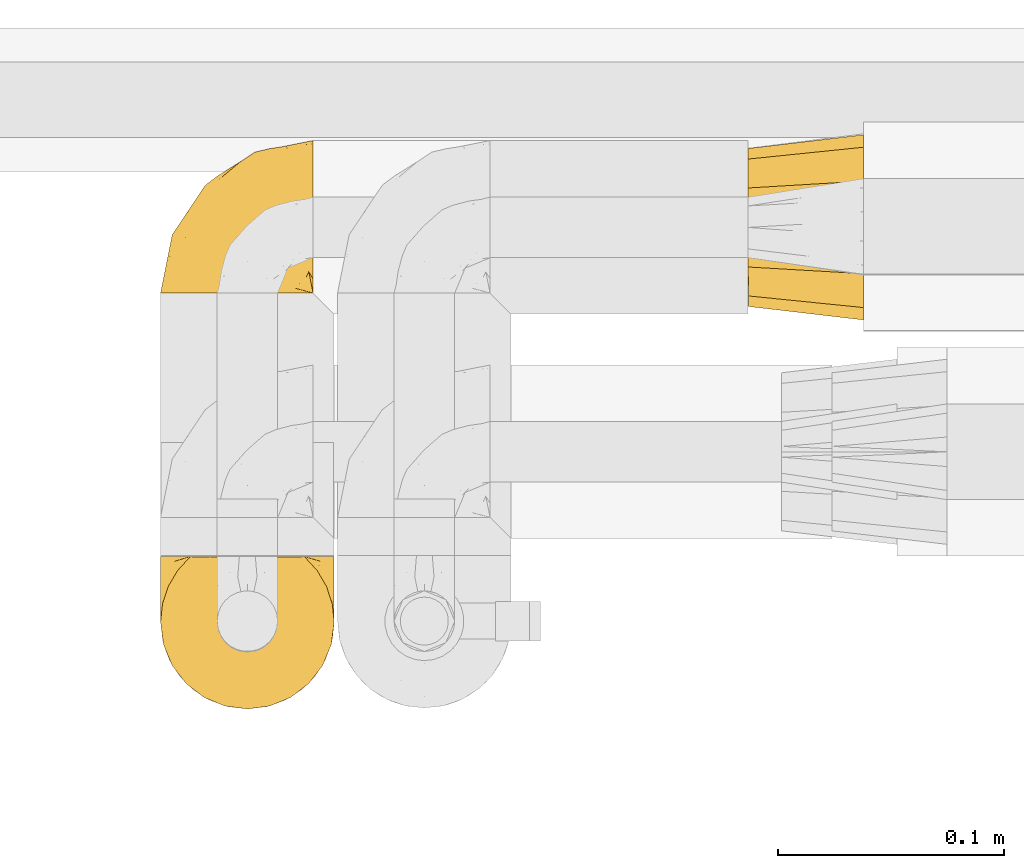
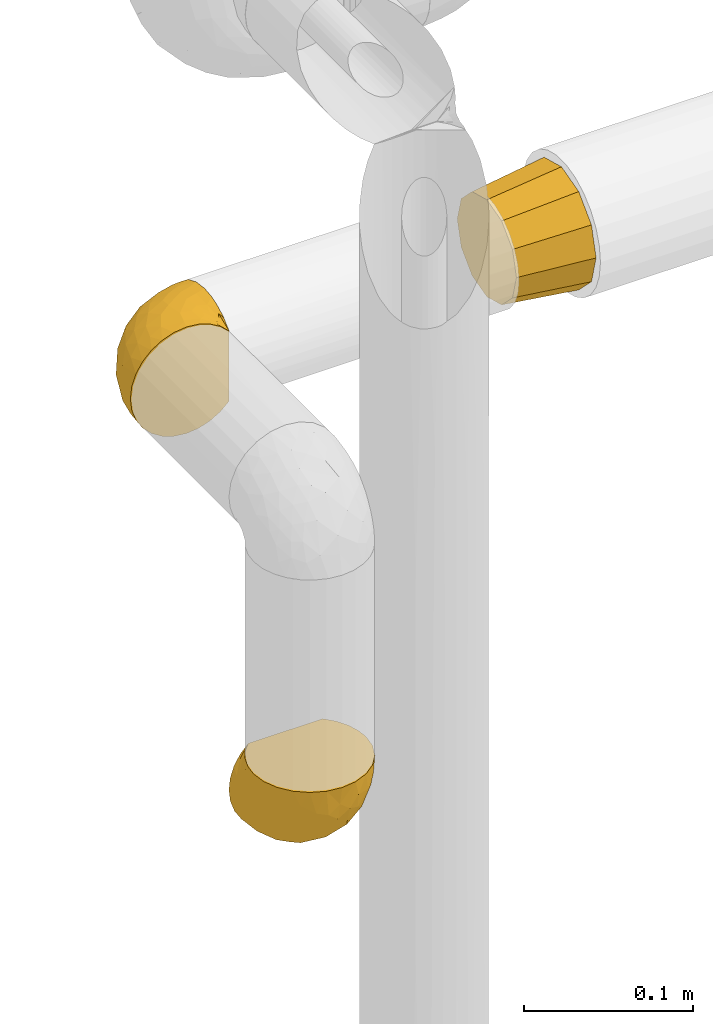
# One storey, part 470 of 827: 3 coverings.
"""IFC2X3 building model written with IfcOpenShell, lengths in millimetres."""

from ifc_helpers import new_model, entity, si_unit, converted_unit, derived_unit, direction, frame, origin, place, context, subcontext, project, spatial, faceted_brep, element, save


model = new_model("IFC2X3")

# Units and contexts
model_context = context("Model", 3, precision=0.01, world=origin(), true_north=direction((6.12303176911189e-17, 1.0)))
body_context = subcontext(model_context, "Body", "Model", "MODEL_VIEW")
ifc_project = project(units=[si_unit("LENGTHUNIT", "METRE", prefix="MILLI"), si_unit("AREAUNIT", "SQUARE_METRE"), si_unit("VOLUMEUNIT", "CUBIC_METRE"), converted_unit("PLANEANGLEUNIT", "DEGREE", entity("IfcRatioMeasure", 0.0174532925199433), si_unit("PLANEANGLEUNIT", "RADIAN"), dimensions=[0, 0, 0, 0, 0, 0, 0]), si_unit("MASSUNIT", "GRAM", prefix="KILO"), derived_unit("MASSDENSITYUNIT", [(si_unit("MASSUNIT", "GRAM", prefix="KILO"), 1), (si_unit("LENGTHUNIT", "METRE"), -3)]), derived_unit("MOMENTOFINERTIAUNIT", [(si_unit("LENGTHUNIT", "METRE"), 4)]), si_unit("TIMEUNIT", "SECOND"), si_unit("FREQUENCYUNIT", "HERTZ"), si_unit("THERMODYNAMICTEMPERATUREUNIT", "DEGREE_CELSIUS"), derived_unit("THERMALTRANSMITTANCEUNIT", [(si_unit("MASSUNIT", "GRAM", prefix="KILO"), 1), (si_unit("THERMODYNAMICTEMPERATUREUNIT", "KELVIN"), -1), (si_unit("TIMEUNIT", "SECOND"), -3)]), derived_unit("VOLUMETRICFLOWRATEUNIT", [(si_unit("LENGTHUNIT", "METRE"), 3), (si_unit("TIMEUNIT", "SECOND"), -1)]), derived_unit("MASSFLOWRATEUNIT", [(si_unit("MASSUNIT", "GRAM", prefix="KILO"), 1), (si_unit("TIMEUNIT", "SECOND"), -1)]), derived_unit("ROTATIONALFREQUENCYUNIT", [(si_unit("TIMEUNIT", "SECOND"), -1)]), si_unit("ELECTRICCURRENTUNIT", "AMPERE"), si_unit("ELECTRICVOLTAGEUNIT", "VOLT"), si_unit("POWERUNIT", "WATT"), si_unit("FORCEUNIT", "NEWTON", prefix="KILO"), si_unit("ILLUMINANCEUNIT", "LUX"), si_unit("LUMINOUSFLUXUNIT", "LUMEN"), si_unit("LUMINOUSINTENSITYUNIT", "CANDELA"), derived_unit("USERDEFINED", [(si_unit("MASSUNIT", "GRAM", prefix="KILO"), -1), (si_unit("LENGTHUNIT", "METRE"), -2), (si_unit("TIMEUNIT", "SECOND"), 3), (si_unit("LUMINOUSFLUXUNIT", "LUMEN"), 1)]), derived_unit("LINEARVELOCITYUNIT", [(si_unit("LENGTHUNIT", "METRE"), 1), (si_unit("TIMEUNIT", "SECOND"), -1)]), si_unit("PRESSUREUNIT", "PASCAL"), derived_unit("USERDEFINED", [(si_unit("LENGTHUNIT", "METRE"), -2), (si_unit("MASSUNIT", "GRAM", prefix="KILO"), 1), (si_unit("TIMEUNIT", "SECOND"), -2)]), derived_unit("LINEARFORCEUNIT", [(si_unit("MASSUNIT", "GRAM", prefix="KILO"), 1), (si_unit("LENGTHUNIT", "METRE"), 1), (si_unit("TIMEUNIT", "SECOND"), -2), (si_unit("LENGTHUNIT", "METRE"), -1)]), derived_unit("PLANARFORCEUNIT", [(si_unit("MASSUNIT", "GRAM", prefix="KILO"), 1), (si_unit("LENGTHUNIT", "METRE"), 1), (si_unit("TIMEUNIT", "SECOND"), -2), (si_unit("LENGTHUNIT", "METRE"), -2)])], contexts=[model_context])

# Site, building, storey
site_placement = place(None, origin())
site = spatial("IfcSite", under=ifc_project, at=site_placement, CompositionType="ELEMENT")
building_placement = place(site_placement, origin())
building = spatial("IfcBuilding", under=site, at=building_placement, CompositionType="ELEMENT")
storey_placement = place(building_placement, frame((0.0, 0.0, 28200.0)))
storey = spatial("IfcBuildingStorey", under=building, at=storey_placement, Name="08", CompositionType="ELEMENT", Elevation=28200.0)

# Coverings
covering_1_placement = place(storey_placement, frame((58451.15, 16448.53, 959.95)))
element("IfcCovering", 1, at=covering_1_placement, inside=storey, Name=":ADSK_", ObjectType=":ADSK_", PredefinedType="INSULATION", context=body_context, shape_type="Brep", body=[
    faceted_brep([(23.36, 1.6, 74.68), (16.07, 1.6, 70.1), (9.98, 1.6, 64.01), (5.4, 1.6, 56.72), (2.56, 1.6, 48.6), (1.6, 1.6, 40.05), (2.56, 1.6, 31.49), (5.41, 1.6, 23.36), (9.99, 1.6, 16.07), (16.08, 1.6, 9.98), (23.37, 1.6, 5.4), (31.49, 1.6, 2.56), (40.05, 1.6, 1.6), (48.15, 1.6, 2.46), (55.88, 1.6, 5.01), (62.9, 1.6, 9.13), (68.89, 1.6, 14.62), (68.89, 1.6, 16.82), (68.89, 1.6, 18.56), (68.89, 1.6, 20.52), (68.89, 1.6, 22.49), (68.89, 1.6, 24.46), (68.89, 1.6, 26.42), (68.89, 1.6, 28.39), (68.89, 1.6, 30.36), (68.89, 1.6, 32.55), (68.89, 1.6, 34.75), (68.89, 1.6, 36.94), (68.89, 1.6, 39.13), (68.89, 1.6, 41.33), (68.89, 1.6, 43.52), (68.89, 1.6, 45.72), (68.89, 1.6, 47.91), (68.89, 1.6, 50.11), (68.89, 1.6, 52.3), (68.89, 1.6, 54.49), (68.89, 1.6, 56.69), (68.89, 1.6, 58.88), (68.89, 1.6, 61.08), (68.89, 1.6, 63.27), (68.89, 1.6, 65.47), (62.89, 1.6, 70.97), (55.86, 1.6, 75.09), (48.13, 1.6, 77.64), (40.05, 1.6, 78.5), (31.49, 1.6, 77.53), (69.15, 1.85, 14.62), (69.15, 7.85, 9.12), (69.15, 14.87, 5.0), (69.15, 22.6, 2.46), (69.15, 30.7, 1.6), (69.15, 40.65, 2.91), (69.15, 49.92, 6.75), (69.15, 57.88, 12.86), (69.15, 63.99, 20.82), (69.15, 67.84, 30.09), (69.15, 69.15, 40.05), (69.15, 67.84, 50.0), (69.15, 63.99, 59.27), (69.15, 57.88, 67.23), (69.15, 49.92, 73.34), (69.15, 40.65, 77.19), (69.15, 30.7, 78.5), (69.15, 22.6, 77.63), (69.15, 14.87, 75.09), (69.15, 7.85, 70.97), (69.15, 1.85, 65.47), (69.15, 1.85, 63.27), (69.15, 1.85, 62.29), (69.15, 1.85, 60.7), (69.15, 1.85, 59.11), (69.15, 1.85, 57.52), (69.15, 1.85, 55.93), (69.15, 1.85, 54.34), (69.15, 1.85, 52.76), (69.15, 1.85, 51.17), (69.15, 1.85, 49.58), (69.15, 1.85, 47.99), (69.15, 1.85, 46.4), (69.15, 1.85, 44.81), (69.15, 1.85, 43.22), (69.15, 1.85, 41.63), (69.15, 1.85, 40.05), (69.15, 1.85, 38.46), (69.15, 1.85, 36.87), (69.15, 1.85, 35.28), (69.15, 1.85, 33.69), (69.15, 1.85, 32.1), (69.15, 1.85, 30.51), (69.15, 1.85, 28.92), (69.15, 1.85, 27.33), (69.15, 1.85, 25.37), (69.15, 1.85, 23.4), (69.15, 1.85, 21.21), (69.15, 1.85, 19.01), (69.15, 1.85, 16.82), (68.96, 1.77, 42.32), (68.97, 1.78, 44.02), (68.97, 1.77, 47.13), (68.97, 1.77, 48.74), (68.95, 1.76, 23.57), (68.96, 1.77, 25.13), (68.98, 1.79, 61.34), (68.97, 1.78, 22.02), (68.97, 1.78, 29.72), (68.98, 1.78, 56.73), (68.97, 1.78, 55.14), (68.97, 1.78, 37.66), (68.94, 1.74, 64.12), (68.98, 1.78, 28.13), (68.98, 1.78, 26.62), (68.96, 1.77, 31.46), (68.97, 1.78, 16.16), (68.98, 1.78, 39.16), (68.98, 1.78, 50.37), (68.97, 1.77, 17.69), (68.96, 1.77, 19.17), (68.97, 1.77, 62.78), (68.97, 1.78, 58.35), (68.98, 1.78, 45.53), (68.96, 1.77, 59.91), (68.97, 1.77, 65.47), (68.94, 1.72, 65.47), (68.92, 1.66, 65.47), (68.97, 1.77, 14.62), (69.02, 1.8, 14.62), (69.08, 1.82, 14.62), (68.98, 1.79, 20.59), (68.97, 1.78, 32.99), (68.98, 1.79, 34.48), (68.97, 1.78, 51.91), (69.08, 1.82, 65.47), (69.02, 1.8, 65.47), (68.96, 1.76, 53.48), (68.92, 1.66, 14.62), (68.94, 1.72, 14.62), (68.97, 1.78, 40.77), (68.96, 1.77, 35.97), (67.02, 9.41, 7.84), (63.33, 17.65, 3.53), (64.61, 7.41, 8.32), (49.27, 21.47, 1.6), (51.4, 15.21, 2.19), (43.94, 16.15, 1.6), (61.87, 28.75, 1.6), (61.54, 13.67, 4.57), (57.95, 12.79, 3.96), (56.12, 19.18, 2.28), (63.4, 29.16, 1.6), (65.41, 9.04, 7.69), (53.1, 7.41, 3.53), (63.04, 5.74, 8.32), (61.33, 3.72, 7.84), (41.99, 8.87, 1.6), (54.6, 26.8, 1.6), (56.6, 9.53, 4.34), (41.58, 7.34, 1.6), (13.72, 37.63, 29.63), (5.82, 17.92, 27.34), (6.74, 27.45, 40.05), (58.82, 37.01, 2.39), (51.58, 34.22, 2.43), (42.09, 45.87, 9.07), (46.12, 56.57, 16.64), (55.56, 52.31, 9.54), (52.38, 42.07, 4.52), (61.54, 44.74, 4.52), (23.76, 21.49, 7.49), (20.5, 11.02, 7.49), (14.64, 15.64, 12.85), (41.77, 26.02, 2.35), (16.28, 36.59, 22.66), (49.4, 65.49, 32.9), (52.34, 63.99, 25.33), (4.3, 15.2, 40.05), (58.67, 60.27, 16.64), (25.26, 45.25, 19.99), (20.17, 35.21, 16.37), (34.7, 22.52, 3.26), (28.67, 12.03, 3.75), (8.62, 13.32, 19.58), (33.37, 35.9, 7.5), (41.35, 33.87, 4.04), (17.15, 25.73, 13.94), (12.68, 26.34, 19.58), (21.47, 46.78, 28.21), (41.11, 59.54, 24.75), (37.53, 60.18, 31.42), (30.64, 53.93, 26.2), (26.66, 53.36, 33.36), (21.38, 49.36, 40.05), (14.06, 38.4, 40.05), (55.54, 66.44, 40.05), (35.17, 50.09, 16.14), (29.04, 41.08, 12.85), (24.34, 31.14, 10.47), (29.33, 28.19, 6.49), (43.3, 64.0, 40.05), (32.34, 56.68, 40.05), (57.75, 43.9, 75.57), (49.41, 65.46, 47.37), (27.85, 52.22, 52.91), (13.7, 37.61, 50.46), (14.63, 15.64, 67.23), (8.61, 13.31, 60.5), (48.85, 50.02, 70.55), (54.13, 59.28, 63.45), (37.84, 53.05, 62.61), (23.75, 21.48, 72.6), (20.49, 11.01, 72.6), (28.66, 12.03, 76.34), (20.83, 41.02, 59.34), (55.15, 35.39, 77.76), (54.6, 26.8, 78.5), (61.87, 28.75, 78.5), (41.58, 7.34, 78.5), (57.58, 65.81, 53.16), (59.91, 53.28, 70.55), (36.94, 59.8, 48.88), (45.72, 61.82, 54.76), (5.82, 17.91, 52.74), (37.91, 41.4, 71.93), (50.18, 40.48, 75.79), (12.67, 26.34, 60.5), (49.29, 31.68, 77.86), (42.64, 27.68, 77.64), (43.94, 16.15, 78.5), (49.27, 21.47, 78.5), (19.45, 28.05, 67.23), (34.7, 22.54, 76.82), (41.99, 8.87, 78.5), (62.29, 37.3, 77.8), (29.01, 41.07, 67.23), (31.47, 32.24, 73.2), (37.18, 47.4, 67.66), (43.45, 35.77, 75.99), (63.33, 17.65, 76.57), (67.23, 11.06, 73.21), (66.07, 8.55, 71.93), (65.22, 6.63, 71.07), (61.99, 12.77, 75.09), (57.95, 12.79, 76.13), (53.09, 7.41, 76.57), (56.84, 18.97, 77.69), (61.33, 3.72, 72.26), (63.06, 5.76, 71.77), (51.41, 15.21, 77.9), (56.61, 9.52, 75.75)], [[[0, 1, 2, 3, 4, 5, 6, 7, 8, 9, 10, 11, 12, 13, 14, 15, 16, 17, 18, 19, 20, 21, 22, 23, 24, 25, 26, 27, 28, 29, 30, 31, 32, 33, 34, 35, 36, 37, 38, 39, 40, 41, 42, 43, 44, 45]], [[46, 47, 48, 49, 50, 51, 52, 53, 54, 55, 56, 57, 58, 59, 60, 61, 62, 63, 64, 65, 66, 67, 68, 69, 70, 71, 72, 73, 74, 75, 76, 77, 78, 79, 80, 81, 82, 83, 84, 85, 86, 87, 88, 89, 90, 91, 92, 93, 94, 95]], [[96, 97, 30]], [[98, 77, 99]], [[100, 101, 21]], [[69, 68, 102]], [[20, 19, 103]], [[24, 23, 104]], [[20, 103, 100]], [[72, 105, 106]], [[84, 83, 107]], [[89, 88, 104]], [[108, 67, 66]], [[109, 110, 90]], [[111, 25, 24]], [[112, 17, 16]], [[82, 113, 83]], [[109, 23, 22]], [[114, 76, 75]], [[105, 36, 106]], [[104, 111, 24]], [[18, 115, 116]], [[97, 96, 80]], [[67, 108, 117]], [[105, 71, 118]], [[31, 97, 119]], [[102, 120, 69]], [[108, 121, 122, 123, 40]], [[112, 95, 115]], [[17, 115, 18]], [[94, 116, 115]], [[117, 68, 67]], [[38, 117, 39]], [[112, 124, 125, 126, 46]], [[17, 112, 115]], [[70, 120, 118]], [[39, 117, 108]], [[120, 38, 37]], [[120, 37, 118]], [[120, 70, 69]], [[116, 94, 127]], [[128, 86, 129]], [[117, 38, 102]], [[74, 130, 75]], [[99, 33, 32]], [[115, 95, 94]], [[39, 108, 40]], [[108, 66, 131, 132, 121]], [[105, 72, 71]], [[118, 37, 36]], [[71, 70, 118]], [[35, 106, 36]], [[36, 105, 118]], [[35, 133, 106]], [[74, 73, 133]], [[106, 133, 73]], [[99, 114, 33]], [[133, 35, 34]], [[73, 72, 106]], [[95, 112, 46]], [[112, 16, 134, 135, 124]], [[130, 114, 75]], [[99, 76, 114]], [[114, 130, 33]], [[34, 33, 130]], [[78, 77, 98]], [[98, 119, 78]], [[130, 133, 34]], [[133, 130, 74]], [[79, 97, 80]], [[98, 99, 32]], [[98, 32, 31]], [[77, 76, 99]], [[97, 79, 119]], [[136, 96, 29]], [[30, 97, 31]], [[136, 29, 28]], [[81, 80, 96]], [[29, 96, 30]], [[31, 119, 98]], [[119, 79, 78]], [[96, 136, 81]], [[82, 81, 136]], [[113, 107, 83]], [[84, 107, 137]], [[107, 27, 137]], [[113, 28, 107]], [[27, 107, 28]], [[85, 84, 137]], [[137, 27, 26]], [[113, 136, 28]], [[136, 113, 82]], [[109, 89, 104]], [[86, 85, 129]], [[89, 109, 90]], [[111, 87, 128]], [[26, 129, 137]], [[88, 111, 104]], [[25, 111, 128]], [[22, 110, 109]], [[23, 109, 104]], [[110, 91, 90]], [[100, 92, 101]], [[110, 22, 101]], [[91, 110, 101]], [[116, 19, 18]], [[111, 88, 87]], [[127, 103, 19]], [[25, 128, 26]], [[86, 128, 87]], [[128, 129, 26]], [[137, 129, 85]], [[120, 102, 38]], [[117, 102, 68]], [[91, 101, 92]], [[21, 101, 22]], [[93, 92, 103]], [[100, 21, 20]], [[100, 103, 92]], [[127, 93, 103]], [[93, 127, 94]], [[116, 127, 19]], [[126, 138, 47]], [[48, 138, 139]], [[140, 125, 124]], [[141, 142, 143]], [[144, 49, 139]], [[145, 140, 146]], [[48, 139, 49]], [[139, 145, 147]], [[49, 144, 148, 50]], [[126, 125, 149]], [[14, 13, 150]], [[151, 146, 140]], [[149, 140, 145]], [[152, 151, 135]], [[152, 14, 150]], [[16, 15, 134]], [[13, 153, 150]], [[124, 151, 140]], [[141, 147, 142]], [[14, 152, 15]], [[15, 152, 134]], [[47, 46, 126]], [[139, 154, 144]], [[138, 48, 47]], [[125, 140, 149]], [[135, 134, 152]], [[146, 155, 142]], [[145, 146, 147]], [[149, 139, 138]], [[147, 141, 154]], [[147, 146, 142]], [[139, 147, 154]], [[139, 149, 145]], [[149, 138, 126]], [[155, 146, 151]], [[150, 143, 142]], [[152, 155, 151]], [[150, 142, 155]], [[13, 12, 156, 153]], [[153, 143, 150]], [[152, 150, 155]], [[151, 124, 135]], [[157, 158, 159]], [[160, 154, 161]], [[162, 163, 164]], [[165, 166, 160]], [[167, 168, 169]], [[141, 170, 161]], [[156, 12, 11]], [[158, 157, 171]], [[172, 55, 173]], [[158, 6, 174]], [[175, 54, 53]], [[52, 166, 164]], [[52, 164, 53]], [[54, 175, 173]], [[166, 52, 51]], [[176, 177, 171]], [[178, 143, 179]], [[156, 11, 179]], [[8, 7, 180]], [[169, 9, 8]], [[179, 143, 153, 156]], [[179, 11, 10]], [[168, 179, 10]], [[181, 162, 182]], [[179, 167, 178]], [[183, 184, 177]], [[183, 169, 184]], [[176, 171, 185]], [[172, 186, 187]], [[158, 7, 6]], [[159, 158, 174]], [[184, 180, 158]], [[54, 173, 55]], [[180, 169, 8]], [[188, 189, 187]], [[9, 168, 10]], [[186, 188, 187]], [[190, 157, 159, 191]], [[55, 172, 192]], [[176, 193, 194]], [[161, 170, 182]], [[162, 164, 165]], [[175, 164, 163]], [[51, 50, 148]], [[167, 195, 196]], [[178, 182, 170]], [[6, 5, 174]], [[158, 180, 7]], [[169, 180, 184]], [[169, 168, 9]], [[179, 168, 167]], [[182, 162, 165]], [[162, 194, 193]], [[161, 165, 160]], [[195, 181, 196]], [[192, 172, 197]], [[192, 56, 55]], [[189, 190, 198]], [[198, 197, 187]], [[172, 187, 197]], [[185, 189, 188]], [[198, 187, 189]], [[186, 172, 173]], [[173, 163, 186]], [[193, 186, 163]], [[176, 185, 188]], [[185, 157, 190]], [[188, 186, 193]], [[177, 176, 194]], [[188, 193, 176]], [[162, 193, 163]], [[195, 177, 194]], [[171, 177, 184]], [[181, 195, 194]], [[183, 167, 169]], [[162, 181, 194]], [[196, 182, 178]], [[158, 171, 184]], [[171, 157, 185]], [[177, 195, 183]], [[167, 183, 195]], [[182, 196, 181]], [[178, 170, 143]], [[178, 167, 196]], [[164, 175, 53]], [[173, 175, 163]], [[160, 51, 148]], [[164, 166, 165]], [[51, 160, 166]], [[160, 148, 144, 154]], [[141, 161, 154]], [[182, 165, 161]], [[190, 189, 185]], [[143, 170, 141]], [[60, 199, 61]], [[197, 200, 192]], [[201, 190, 202]], [[200, 57, 192]], [[203, 204, 2]], [[205, 206, 207]], [[208, 209, 210]], [[211, 207, 201]], [[212, 213, 214]], [[45, 215, 210]], [[216, 206, 58]], [[45, 44, 215]], [[59, 217, 60]], [[60, 217, 199]], [[0, 45, 210]], [[218, 201, 219]], [[202, 159, 220]], [[205, 221, 222]], [[223, 204, 203]], [[1, 203, 2]], [[57, 200, 216]], [[220, 3, 204]], [[220, 174, 4]], [[1, 0, 209]], [[212, 224, 213]], [[225, 226, 227]], [[228, 223, 203]], [[208, 210, 229]], [[210, 226, 229]], [[3, 220, 4]], [[58, 206, 59]], [[209, 203, 1]], [[202, 220, 223]], [[228, 203, 208]], [[202, 211, 201]], [[3, 2, 204]], [[202, 190, 191, 159]], [[210, 215, 230, 226]], [[199, 212, 231]], [[232, 233, 221]], [[233, 208, 229]], [[207, 206, 219]], [[217, 206, 205]], [[227, 224, 225]], [[233, 232, 228]], [[201, 207, 219]], [[234, 232, 221]], [[218, 219, 200]], [[202, 223, 211]], [[174, 220, 159]], [[174, 5, 4]], [[61, 231, 62]], [[220, 204, 223]], [[210, 209, 0]], [[203, 209, 208]], [[225, 233, 229]], [[224, 227, 213]], [[221, 233, 235]], [[57, 56, 192]], [[198, 218, 197]], [[200, 219, 216]], [[201, 198, 190]], [[197, 218, 200]], [[198, 201, 218]], [[206, 216, 219]], [[58, 57, 216]], [[231, 212, 214]], [[222, 212, 199]], [[228, 211, 223]], [[207, 211, 232]], [[62, 231, 214]], [[199, 231, 61]], [[233, 228, 208]], [[211, 228, 232]], [[222, 221, 235]], [[234, 205, 207]], [[206, 217, 59]], [[199, 217, 205]], [[205, 222, 199]], [[224, 222, 235]], [[222, 224, 212]], [[224, 235, 225]], [[233, 225, 235]], [[226, 225, 229]], [[205, 234, 221]], [[207, 232, 234]], [[63, 214, 236]], [[214, 213, 236]], [[214, 63, 62]], [[237, 236, 238]], [[238, 132, 131]], [[236, 237, 64]], [[239, 240, 241]], [[63, 236, 64]], [[131, 66, 65]], [[237, 131, 65]], [[242, 230, 43]], [[237, 65, 64]], [[239, 121, 132]], [[42, 242, 43]], [[241, 240, 243]], [[41, 123, 244]], [[43, 230, 215, 44]], [[244, 122, 245]], [[227, 246, 243]], [[241, 247, 245]], [[121, 239, 245]], [[41, 40, 123]], [[132, 238, 239]], [[244, 42, 41]], [[131, 237, 238]], [[240, 239, 238]], [[245, 239, 241]], [[247, 241, 246]], [[247, 244, 245]], [[238, 236, 240]], [[243, 236, 213]], [[236, 243, 240]], [[227, 226, 246]], [[243, 213, 227]], [[242, 246, 226]], [[243, 246, 241]], [[246, 242, 247]], [[244, 247, 242]], [[242, 226, 230]], [[42, 244, 242]], [[122, 244, 123]], [[122, 121, 245]]]),
])
covering_2_placement = place(storey_placement, frame((58451.15, 16264.34, 748.41)))
element("IfcCovering", 2, at=covering_2_placement, inside=storey, Name=":ADSK_", ObjectType=":ADSK_", PredefinedType="INSULATION", context=body_context, shape_type="Brep", body=[
    faceted_brep([(74.68, 69.15, 23.36), (70.1, 69.15, 16.07), (64.01, 69.15, 9.98), (56.72, 69.15, 5.4), (48.6, 69.15, 2.56), (40.05, 69.15, 1.6), (31.49, 69.15, 2.56), (23.36, 69.15, 5.41), (16.07, 69.15, 9.99), (9.98, 69.15, 16.08), (5.4, 69.15, 23.37), (2.56, 69.15, 31.49), (1.6, 69.15, 40.05), (2.46, 69.15, 48.15), (5.01, 69.15, 55.88), (9.13, 69.15, 62.9), (14.62, 69.15, 68.89), (16.82, 69.15, 68.89), (18.56, 69.15, 68.89), (20.52, 69.15, 68.89), (22.49, 69.15, 68.89), (24.46, 69.15, 68.89), (26.42, 69.15, 68.89), (28.39, 69.15, 68.89), (30.36, 69.15, 68.89), (32.55, 69.15, 68.89), (34.75, 69.15, 68.89), (36.94, 69.15, 68.89), (39.13, 69.15, 68.89), (41.33, 69.15, 68.89), (43.52, 69.15, 68.89), (45.72, 69.15, 68.89), (47.91, 69.15, 68.89), (50.11, 69.15, 68.89), (52.3, 69.15, 68.89), (54.49, 69.15, 68.89), (56.69, 69.15, 68.89), (58.88, 69.15, 68.89), (61.08, 69.15, 68.89), (63.27, 69.15, 68.89), (65.47, 69.15, 68.89), (70.97, 69.15, 62.89), (75.09, 69.15, 55.86), (77.64, 69.15, 48.13), (78.5, 69.15, 40.05), (77.53, 69.15, 31.49), (14.62, 68.89, 69.15), (9.12, 62.89, 69.15), (5.0, 55.87, 69.15), (2.46, 48.14, 69.15), (1.6, 40.05, 69.15), (2.91, 30.09, 69.15), (6.75, 20.82, 69.15), (12.86, 12.86, 69.15), (20.82, 6.75, 69.15), (30.09, 2.91, 69.15), (40.05, 1.6, 69.15), (50.0, 2.91, 69.15), (59.27, 6.75, 69.15), (67.23, 12.86, 69.15), (73.34, 20.82, 69.15), (77.19, 30.09, 69.15), (78.5, 40.05, 69.15), (77.63, 48.14, 69.15), (75.09, 55.87, 69.15), (70.97, 62.89, 69.15), (65.47, 68.89, 69.15), (63.27, 68.89, 69.15), (62.29, 68.89, 69.15), (60.7, 68.89, 69.15), (59.11, 68.89, 69.15), (57.52, 68.89, 69.15), (55.93, 68.89, 69.15), (54.34, 68.89, 69.15), (52.76, 68.89, 69.15), (51.17, 68.89, 69.15), (49.58, 68.89, 69.15), (47.99, 68.89, 69.15), (46.4, 68.89, 69.15), (44.81, 68.89, 69.15), (43.22, 68.89, 69.15), (41.63, 68.89, 69.15), (40.05, 68.89, 69.15), (38.46, 68.89, 69.15), (36.87, 68.89, 69.15), (35.28, 68.89, 69.15), (33.69, 68.89, 69.15), (32.1, 68.89, 69.15), (30.51, 68.89, 69.15), (28.92, 68.89, 69.15), (27.33, 68.89, 69.15), (25.37, 68.89, 69.15), (23.4, 68.89, 69.15), (21.21, 68.89, 69.15), (19.01, 68.89, 69.15), (16.82, 68.89, 69.15), (42.32, 68.97, 68.96), (44.02, 68.96, 68.97), (47.13, 68.97, 68.97), (48.74, 68.97, 68.97), (23.57, 68.98, 68.95), (25.13, 68.97, 68.96), (61.34, 68.96, 68.98), (22.02, 68.96, 68.97), (29.72, 68.96, 68.97), (56.73, 68.96, 68.98), (55.14, 68.96, 68.97), (37.66, 68.96, 68.97), (64.12, 69.0, 68.94), (28.13, 68.96, 68.98), (26.62, 68.96, 68.98), (31.46, 68.97, 68.96), (16.16, 68.96, 68.97), (39.16, 68.96, 68.98), (50.37, 68.96, 68.98), (17.69, 68.97, 68.97), (19.17, 68.97, 68.96), (62.78, 68.97, 68.97), (58.35, 68.96, 68.97), (45.53, 68.96, 68.98), (59.91, 68.97, 68.96), (65.47, 68.97, 68.97), (65.47, 69.02, 68.94), (65.47, 69.08, 68.92), (14.62, 68.97, 68.97), (14.62, 68.94, 69.02), (14.62, 68.92, 69.08), (20.59, 68.96, 68.98), (32.99, 68.96, 68.97), (34.48, 68.95, 68.98), (51.91, 68.96, 68.97), (65.47, 68.92, 69.08), (65.47, 68.94, 69.02), (53.48, 68.98, 68.96), (14.62, 69.08, 68.92), (14.62, 69.02, 68.94), (40.77, 68.96, 68.97), (35.97, 68.97, 68.96), (7.84, 61.33, 67.02), (3.53, 53.1, 63.33), (8.32, 63.33, 64.61), (1.6, 49.27, 49.27), (2.19, 55.53, 51.4), (1.6, 54.6, 43.94), (1.6, 41.99, 61.87), (4.57, 57.07, 61.54), (3.96, 57.95, 57.95), (2.28, 51.56, 56.12), (1.6, 41.58, 63.4), (7.69, 61.7, 65.41), (3.53, 63.33, 53.1), (8.32, 65.0, 63.04), (7.84, 67.02, 61.33), (1.6, 61.87, 41.99), (1.6, 43.94, 54.6), (4.34, 61.21, 56.6), (1.6, 63.4, 41.58), (29.63, 33.11, 13.72), (27.34, 52.82, 5.82), (40.05, 43.3, 6.74), (2.39, 33.73, 58.82), (2.43, 36.52, 51.58), (9.07, 24.87, 42.09), (16.64, 14.17, 46.12), (9.54, 18.43, 55.56), (4.52, 28.67, 52.38), (4.52, 26.0, 61.54), (7.49, 49.25, 23.76), (7.49, 59.72, 20.5), (12.85, 55.1, 14.64), (2.35, 44.72, 41.77), (22.66, 34.15, 16.28), (32.9, 5.25, 49.4), (25.33, 6.75, 52.34), (40.05, 55.54, 4.3), (16.64, 10.47, 58.67), (19.99, 25.49, 25.26), (16.37, 35.53, 20.17), (3.26, 48.22, 34.7), (3.75, 58.71, 28.67), (19.58, 57.42, 8.62), (7.5, 34.84, 33.37), (4.04, 36.87, 41.35), (13.94, 45.01, 17.15), (19.58, 44.4, 12.68), (28.21, 23.96, 21.47), (24.75, 11.2, 41.11), (31.42, 10.56, 37.53), (26.2, 16.81, 30.64), (33.36, 17.38, 26.66), (40.05, 21.38, 21.38), (40.05, 32.34, 14.06), (40.05, 4.3, 55.54), (16.14, 20.65, 35.17), (12.85, 29.66, 29.04), (10.47, 39.6, 24.34), (6.49, 42.55, 29.33), (40.05, 6.74, 43.3), (40.05, 14.06, 32.34), (75.57, 26.84, 57.75), (47.37, 5.28, 49.41), (52.91, 18.52, 27.85), (50.46, 33.13, 13.7), (67.23, 55.1, 14.63), (60.5, 57.43, 8.61), (70.55, 20.72, 48.85), (63.45, 11.46, 54.13), (62.61, 17.69, 37.84), (72.6, 49.26, 23.75), (72.6, 59.73, 20.49), (76.34, 58.71, 28.66), (59.34, 29.72, 20.83), (77.76, 35.35, 55.15), (78.5, 43.94, 54.6), (78.5, 41.99, 61.87), (78.5, 63.4, 41.58), (53.16, 4.93, 57.58), (70.55, 17.46, 59.91), (48.88, 10.94, 36.94), (54.76, 8.92, 45.72), (52.74, 52.83, 5.82), (71.93, 29.34, 37.91), (75.79, 30.26, 50.18), (60.5, 44.4, 12.67), (77.86, 39.06, 49.29), (77.64, 43.06, 42.64), (78.5, 54.6, 43.94), (78.5, 49.27, 49.27), (67.23, 42.69, 19.45), (76.82, 48.2, 34.7), (78.5, 61.87, 41.99), (77.8, 33.44, 62.29), (67.23, 29.67, 29.01), (73.2, 38.5, 31.47), (67.66, 23.35, 37.18), (75.99, 34.97, 43.45), (76.57, 53.1, 63.33), (73.21, 59.68, 67.23), (71.93, 62.19, 66.07), (71.07, 64.11, 65.22), (75.09, 57.97, 61.99), (76.13, 57.95, 57.95), (76.57, 63.33, 53.09), (77.69, 51.77, 56.84), (72.26, 67.02, 61.33), (71.77, 64.98, 63.06), (77.9, 55.53, 51.41), (75.75, 61.22, 56.61)], [[[0, 1, 2, 3, 4, 5, 6, 7, 8, 9, 10, 11, 12, 13, 14, 15, 16, 17, 18, 19, 20, 21, 22, 23, 24, 25, 26, 27, 28, 29, 30, 31, 32, 33, 34, 35, 36, 37, 38, 39, 40, 41, 42, 43, 44, 45]], [[46, 47, 48, 49, 50, 51, 52, 53, 54, 55, 56, 57, 58, 59, 60, 61, 62, 63, 64, 65, 66, 67, 68, 69, 70, 71, 72, 73, 74, 75, 76, 77, 78, 79, 80, 81, 82, 83, 84, 85, 86, 87, 88, 89, 90, 91, 92, 93, 94, 95]], [[96, 97, 30]], [[98, 77, 99]], [[100, 101, 21]], [[69, 68, 102]], [[20, 19, 103]], [[24, 23, 104]], [[20, 103, 100]], [[72, 105, 106]], [[84, 83, 107]], [[89, 88, 104]], [[108, 67, 66]], [[109, 110, 90]], [[111, 25, 24]], [[112, 17, 16]], [[82, 113, 83]], [[109, 23, 22]], [[114, 76, 75]], [[105, 36, 106]], [[104, 111, 24]], [[18, 115, 116]], [[97, 96, 80]], [[67, 108, 117]], [[105, 71, 118]], [[31, 97, 119]], [[102, 120, 69]], [[108, 121, 122, 123, 40]], [[112, 95, 115]], [[17, 115, 18]], [[94, 116, 115]], [[117, 68, 67]], [[38, 117, 39]], [[112, 124, 125, 126, 46]], [[17, 112, 115]], [[70, 120, 118]], [[39, 117, 108]], [[120, 38, 37]], [[120, 37, 118]], [[120, 70, 69]], [[116, 94, 127]], [[128, 86, 129]], [[117, 38, 102]], [[74, 130, 75]], [[99, 33, 32]], [[115, 95, 94]], [[39, 108, 40]], [[108, 66, 131, 132, 121]], [[105, 72, 71]], [[118, 37, 36]], [[71, 70, 118]], [[35, 106, 36]], [[36, 105, 118]], [[35, 133, 106]], [[74, 73, 133]], [[106, 133, 73]], [[99, 114, 33]], [[133, 35, 34]], [[73, 72, 106]], [[95, 112, 46]], [[112, 16, 134, 135, 124]], [[130, 114, 75]], [[99, 76, 114]], [[114, 130, 33]], [[34, 33, 130]], [[78, 77, 98]], [[98, 119, 78]], [[130, 133, 34]], [[133, 130, 74]], [[79, 97, 80]], [[98, 99, 32]], [[98, 32, 31]], [[77, 76, 99]], [[97, 79, 119]], [[136, 96, 29]], [[30, 97, 31]], [[136, 29, 28]], [[81, 80, 96]], [[29, 96, 30]], [[31, 119, 98]], [[119, 79, 78]], [[96, 136, 81]], [[82, 81, 136]], [[113, 107, 83]], [[84, 107, 137]], [[107, 27, 137]], [[113, 28, 107]], [[27, 107, 28]], [[85, 84, 137]], [[137, 27, 26]], [[113, 136, 28]], [[136, 113, 82]], [[109, 89, 104]], [[86, 85, 129]], [[89, 109, 90]], [[111, 87, 128]], [[26, 129, 137]], [[88, 111, 104]], [[25, 111, 128]], [[22, 110, 109]], [[23, 109, 104]], [[110, 91, 90]], [[100, 92, 101]], [[110, 22, 101]], [[91, 110, 101]], [[116, 19, 18]], [[111, 88, 87]], [[127, 103, 19]], [[25, 128, 26]], [[86, 128, 87]], [[128, 129, 26]], [[137, 129, 85]], [[120, 102, 38]], [[117, 102, 68]], [[91, 101, 92]], [[21, 101, 22]], [[93, 92, 103]], [[100, 21, 20]], [[100, 103, 92]], [[127, 93, 103]], [[93, 127, 94]], [[116, 127, 19]], [[126, 138, 47]], [[48, 138, 139]], [[140, 125, 124]], [[141, 142, 143]], [[144, 49, 139]], [[145, 140, 146]], [[48, 139, 49]], [[139, 145, 147]], [[49, 144, 148, 50]], [[126, 125, 149]], [[14, 13, 150]], [[151, 146, 140]], [[149, 140, 145]], [[152, 151, 135]], [[152, 14, 150]], [[16, 15, 134]], [[13, 153, 150]], [[124, 151, 140]], [[141, 147, 142]], [[14, 152, 15]], [[15, 152, 134]], [[47, 46, 126]], [[139, 154, 144]], [[138, 48, 47]], [[125, 140, 149]], [[135, 134, 152]], [[146, 155, 142]], [[145, 146, 147]], [[149, 139, 138]], [[147, 141, 154]], [[147, 146, 142]], [[139, 147, 154]], [[139, 149, 145]], [[149, 138, 126]], [[155, 146, 151]], [[150, 143, 142]], [[152, 155, 151]], [[150, 142, 155]], [[13, 12, 156, 153]], [[153, 143, 150]], [[152, 150, 155]], [[151, 124, 135]], [[157, 158, 159]], [[160, 154, 161]], [[162, 163, 164]], [[165, 166, 160]], [[167, 168, 169]], [[141, 170, 161]], [[156, 12, 11]], [[158, 157, 171]], [[172, 55, 173]], [[158, 6, 174]], [[175, 54, 53]], [[52, 166, 164]], [[52, 164, 53]], [[54, 175, 173]], [[166, 52, 51]], [[176, 177, 171]], [[178, 143, 179]], [[156, 11, 179]], [[8, 7, 180]], [[169, 9, 8]], [[179, 143, 153, 156]], [[179, 11, 10]], [[168, 179, 10]], [[181, 162, 182]], [[179, 167, 178]], [[183, 184, 177]], [[183, 169, 184]], [[176, 171, 185]], [[172, 186, 187]], [[158, 7, 6]], [[159, 158, 174]], [[184, 180, 158]], [[54, 173, 55]], [[180, 169, 8]], [[188, 189, 187]], [[9, 168, 10]], [[186, 188, 187]], [[190, 157, 159, 191]], [[55, 172, 192]], [[176, 193, 194]], [[161, 170, 182]], [[162, 164, 165]], [[175, 164, 163]], [[51, 50, 148]], [[167, 195, 196]], [[178, 182, 170]], [[6, 5, 174]], [[158, 180, 7]], [[169, 180, 184]], [[169, 168, 9]], [[179, 168, 167]], [[182, 162, 165]], [[162, 194, 193]], [[161, 165, 160]], [[195, 181, 196]], [[192, 172, 197]], [[192, 56, 55]], [[189, 190, 198]], [[198, 197, 187]], [[172, 187, 197]], [[185, 189, 188]], [[198, 187, 189]], [[186, 172, 173]], [[173, 163, 186]], [[193, 186, 163]], [[176, 185, 188]], [[185, 157, 190]], [[188, 186, 193]], [[177, 176, 194]], [[188, 193, 176]], [[162, 193, 163]], [[195, 177, 194]], [[171, 177, 184]], [[181, 195, 194]], [[183, 167, 169]], [[162, 181, 194]], [[196, 182, 178]], [[158, 171, 184]], [[171, 157, 185]], [[177, 195, 183]], [[167, 183, 195]], [[182, 196, 181]], [[178, 170, 143]], [[178, 167, 196]], [[164, 175, 53]], [[173, 175, 163]], [[160, 51, 148]], [[164, 166, 165]], [[51, 160, 166]], [[160, 148, 144, 154]], [[141, 161, 154]], [[182, 165, 161]], [[190, 189, 185]], [[143, 170, 141]], [[60, 199, 61]], [[197, 200, 192]], [[201, 190, 202]], [[200, 57, 192]], [[203, 204, 2]], [[205, 206, 207]], [[208, 209, 210]], [[211, 207, 201]], [[212, 213, 214]], [[45, 215, 210]], [[216, 206, 58]], [[45, 44, 215]], [[59, 217, 60]], [[60, 217, 199]], [[0, 45, 210]], [[218, 201, 219]], [[202, 159, 220]], [[205, 221, 222]], [[223, 204, 203]], [[1, 203, 2]], [[57, 200, 216]], [[220, 3, 204]], [[220, 174, 4]], [[1, 0, 209]], [[212, 224, 213]], [[225, 226, 227]], [[228, 223, 203]], [[208, 210, 229]], [[210, 226, 229]], [[3, 220, 4]], [[58, 206, 59]], [[209, 203, 1]], [[202, 220, 223]], [[228, 203, 208]], [[202, 211, 201]], [[3, 2, 204]], [[202, 190, 191, 159]], [[210, 215, 230, 226]], [[199, 212, 231]], [[232, 233, 221]], [[233, 208, 229]], [[207, 206, 219]], [[217, 206, 205]], [[227, 224, 225]], [[233, 232, 228]], [[201, 207, 219]], [[234, 232, 221]], [[218, 219, 200]], [[202, 223, 211]], [[174, 220, 159]], [[174, 5, 4]], [[61, 231, 62]], [[220, 204, 223]], [[210, 209, 0]], [[203, 209, 208]], [[225, 233, 229]], [[224, 227, 213]], [[221, 233, 235]], [[57, 56, 192]], [[198, 218, 197]], [[200, 219, 216]], [[201, 198, 190]], [[197, 218, 200]], [[198, 201, 218]], [[206, 216, 219]], [[58, 57, 216]], [[231, 212, 214]], [[222, 212, 199]], [[228, 211, 223]], [[207, 211, 232]], [[62, 231, 214]], [[199, 231, 61]], [[233, 228, 208]], [[211, 228, 232]], [[222, 221, 235]], [[234, 205, 207]], [[206, 217, 59]], [[199, 217, 205]], [[205, 222, 199]], [[224, 222, 235]], [[222, 224, 212]], [[224, 235, 225]], [[233, 225, 235]], [[226, 225, 229]], [[205, 234, 221]], [[207, 232, 234]], [[63, 214, 236]], [[214, 213, 236]], [[214, 63, 62]], [[237, 236, 238]], [[238, 132, 131]], [[236, 237, 64]], [[239, 240, 241]], [[63, 236, 64]], [[131, 66, 65]], [[237, 131, 65]], [[242, 230, 43]], [[237, 65, 64]], [[239, 121, 132]], [[42, 242, 43]], [[241, 240, 243]], [[41, 123, 244]], [[43, 230, 215, 44]], [[244, 122, 245]], [[227, 246, 243]], [[241, 243, 246]], [[121, 239, 245]], [[41, 40, 123]], [[132, 238, 239]], [[244, 42, 41]], [[131, 237, 238]], [[240, 239, 238]], [[245, 239, 241]], [[247, 241, 246]], [[247, 244, 245]], [[238, 236, 240]], [[243, 236, 213]], [[236, 243, 240]], [[226, 246, 227]], [[243, 213, 227]], [[226, 242, 246]], [[241, 247, 245]], [[246, 242, 247]], [[244, 247, 242]], [[242, 226, 230]], [[42, 244, 242]], [[122, 244, 123]], [[122, 121, 245]]]),
])
covering_3_placement = place(storey_placement, frame((58713.0, 16436.63, 957.4)))
element("IfcCovering", 3, at=covering_3_placement, inside=storey, Name=":ADSK_", ObjectType=":ADSK_", PredefinedType="INSULATION", context=body_context, shape_type="Brep", body=[
    faceted_brep([(0.0, 75.22, 51.35), (0.0, 77.56, 42.6), (0.0, 75.22, 33.85), (0.0, 72.87, 25.1), (0.01, 66.47, 18.69), (0.01, 60.06, 12.28), (0.02, 51.31, 9.94), (0.02, 42.56, 7.6), (0.03, 33.81, 9.94), (0.03, 25.06, 12.28), (0.04, 18.66, 18.69), (0.04, 12.25, 25.1), (0.04, 9.91, 33.85), (0.04, 7.56, 42.6), (0.04, 9.91, 51.35), (0.04, 12.25, 60.1), (0.04, 18.66, 66.5), (0.03, 25.06, 72.91), (0.03, 33.81, 75.25), (0.02, 42.56, 77.6), (0.02, 51.31, 75.25), (0.01, 60.06, 72.91), (0.01, 66.47, 66.5), (0.0, 72.87, 60.1), (51.05, 7.09, 63.1), (51.05, 5.43, 56.92), (51.05, 3.51, 49.76), (51.05, 1.6, 42.6), (51.05, 3.51, 35.43), (51.05, 5.43, 28.27), (51.05, 7.09, 22.1), (51.04, 14.59, 14.59), (51.04, 22.1, 7.09), (51.03, 28.27, 5.43), (51.03, 35.43, 3.51), (51.02, 42.6, 1.6), (51.02, 49.76, 3.51), (51.01, 56.92, 5.43), (51.01, 63.1, 7.09), (51.0, 70.6, 14.59), (51.0, 78.1, 22.1), (51.0, 79.76, 28.27), (51.0, 81.68, 35.43), (51.0, 83.6, 42.6), (51.0, 81.68, 49.76), (51.0, 79.76, 56.92), (51.0, 78.1, 63.1), (51.0, 70.6, 70.6), (51.01, 63.1, 78.1), (51.01, 56.92, 79.76), (51.02, 49.76, 81.68), (51.02, 42.6, 83.6), (51.03, 35.43, 81.68), (51.03, 28.27, 79.76), (51.04, 22.1, 78.1), (51.04, 14.59, 70.6)], [[[0, 1, 2, 3, 4, 5, 6, 7, 8, 9, 10, 11, 12, 13, 14, 15, 16, 17, 18, 19, 20, 21, 22, 23]], [[24, 25, 26, 27, 28, 29, 30, 31, 32, 33, 34, 35, 36, 37, 38, 39, 40, 41, 42, 43, 44, 45, 46, 47, 48, 49, 50, 51, 52, 53, 54, 55]], [[5, 38, 37, 36, 35, 7, 6]], [[40, 39, 38, 5, 4, 3]], [[42, 41, 40, 3, 2, 1, 43]], [[11, 30, 29, 28, 27, 13, 12]], [[32, 31, 30, 11, 10, 9]], [[34, 33, 32, 9, 8, 7, 35]], [[17, 54, 53, 52, 51, 19, 18]], [[24, 55, 54, 17, 16, 15]], [[26, 25, 24, 15, 14, 13, 27]], [[23, 46, 45, 44, 43, 1, 0]], [[48, 47, 46, 23, 22, 21]], [[50, 49, 48, 21, 20, 19, 51]]]),
])

save(model, "model.ifc")
